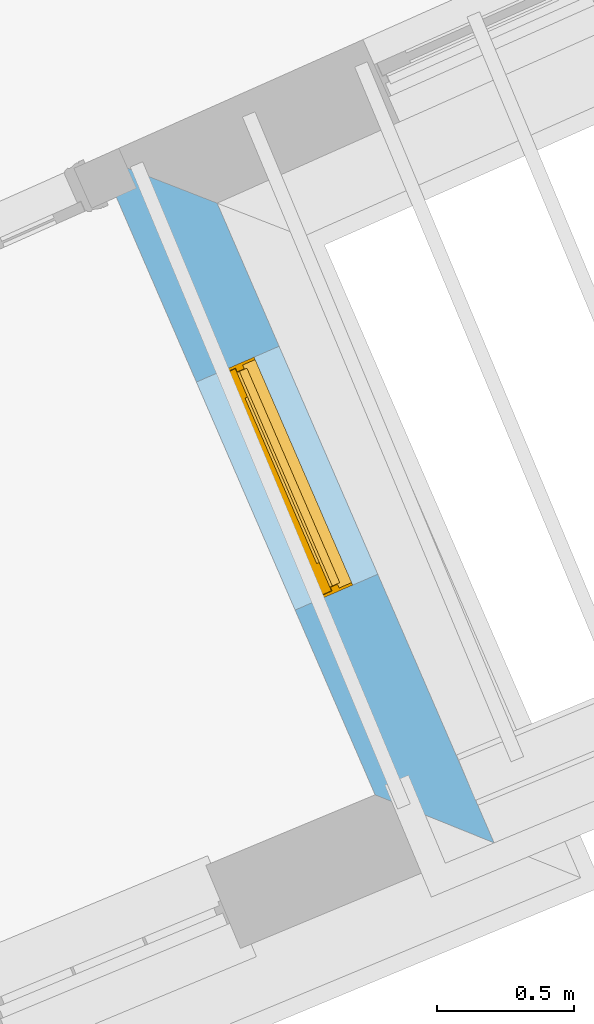
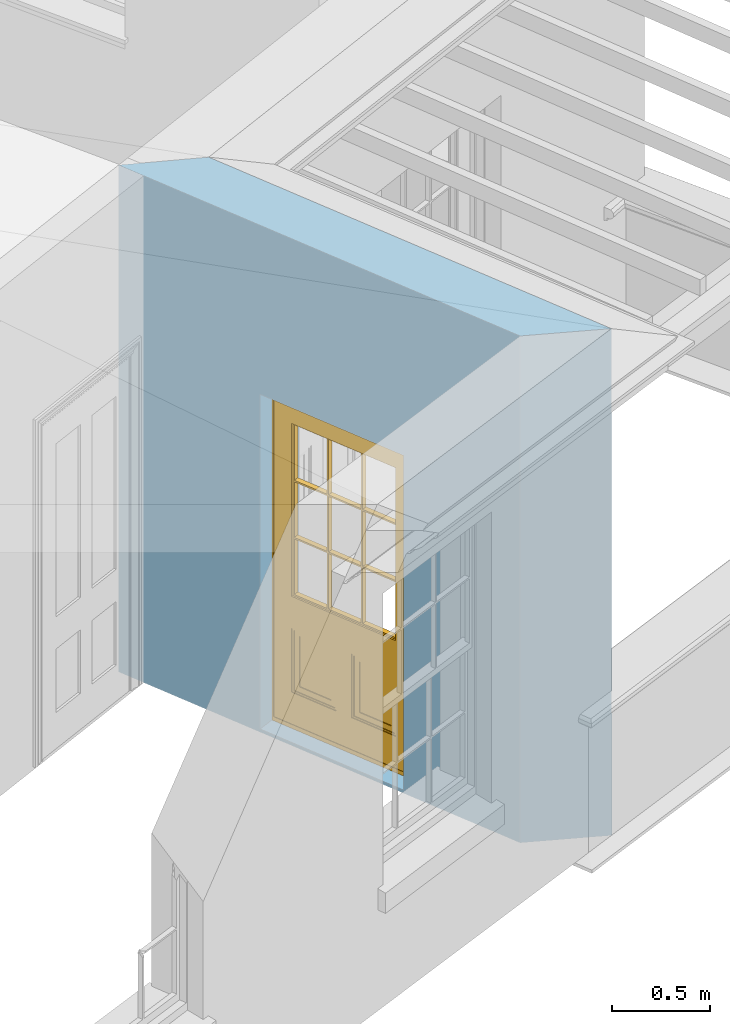
# One storey, part 5 of 10: 1 door, 1 opening, plus 1 element that does not belong to this part.
"""IFC2X3 building model written with IfcOpenShell, lengths in metres."""

from ifc_helpers import new_model, si_unit, frame, origin, place, context, subcontext, project, spatial, polyline, outline, extrude, faceted_brep, material, layer, layer_set, layer_usage, element, fill, save


model = new_model("IFC2X3")

# Units and contexts
model_context = context("Model", 3, world=origin())
body_context = subcontext(model_context, "Body", "Model", "MODEL_VIEW")
ifc_project = project(units=[si_unit("PLANEANGLEUNIT", "RADIAN"), si_unit("MASSUNIT", "GRAM", prefix="KILO"), si_unit("FORCEUNIT", "NEWTON", prefix="KILO"), si_unit("LENGTHUNIT", "METRE")], contexts=[model_context])

# Site, building, storey
site_placement = place(None, origin())
site = spatial("IfcSite", under=ifc_project, at=site_placement, CompositionType="ELEMENT")
building_placement = place(None, origin())
building = spatial("IfcBuilding", under=site, at=building_placement, Name="Building plot-1", CompositionType="ELEMENT")
storey_placement = place(None, frame((0.0, 0.0, 8.45)))
storey = spatial("IfcBuildingStorey", under=building, at=storey_placement, Name="Floor 2", CompositionType="ELEMENT", Elevation=8.45)

# Wall, opening, door
ifc_material = material(Name="Masonry")
ifc_layer = layer(ifc_material, 0.33, ventilated=False)
ifc_layer_set = layer_set([ifc_layer], Name="My Wall")
ifc_layer_usage = layer_usage(ifc_layer_set, "AXIS2", "NEGATIVE", 0.08)
wall_placement = place(storey_placement, origin())
wall = element("IfcWallStandardCase", 1, at=wall_placement, inside=storey, material=ifc_layer_usage, Name="exterior", context=body_context, shape_type="SweptSolid", body=[
    extrude(outline(polyline([(28.6286616795671, 43.2204467376737), (29.0644458342875, 43.0445099541443), (28.0499575041078, 45.3875090802526), (27.617356280873, 45.5560947632642), (28.6286616795671, 43.2204467376737)])), origin(), (0.0, 0.0, 1.0), 3.15),
])
opening_placement = place(storey_placement, frame((0.0, 0.0, 0.0199999999999996)))
opening = element("IfcOpeningElement", 2, at=opening_placement, cuts=wall, Name="Opening", ObjectType="Opening", context=body_context, shape_type="SweptSolid", body=[
    extrude(outline(polyline([(28.6384753465714, 44.0283048887692), (28.2768960371276, 44.8633859644631), (27.9740644382496, 44.7322637973022), (28.3356437476933, 43.8971827216083), (28.6384753465714, 44.0283048887692)])), origin(), (0.0, 0.0, 1.0), 2.08),
])
door_placement = place(storey_placement, frame((28.4090574686335, 43.9289699136473, 0.0199999999999996), z_axis=(0.0, 0.0, 1.0), x_axis=(-0.361579309443719, 0.835081075693971, 0.0)))
door = element("IfcDoor", 3, at=door_placement, inside=storey, Name="circulation outside door", OverallHeight=2.08, OverallWidth=0.91, context=body_context, shape_type="Brep", held_by="IfcProductRepresentation", body=[
    faceted_brep([(0.545, -0.055, 0.265), (0.745, -0.055, 0.265), (0.745, -0.05, 0.265), (0.545, -0.05, 0.265), (0.745, -0.05, 0.58), (0.545, -0.05, 0.58), (0.545, -0.055, 0.58), (0.515, -0.06, 0.235), (0.775, -0.06, 0.235), (0.745, -0.055, 0.58), (0.515, -0.06, 0.61), (0.515, -0.065, 0.235), (0.775, -0.065, 0.235), (0.775, -0.06, 0.61), (0.515, -0.065, 0.61), (0.785, -0.065, 0.225), (0.505, -0.065, 0.225), (0.775, -0.065, 0.61), (0.505, -0.065, 0.62), (0.785, -0.065, 0.62), (0.505, -0.07, 0.225), (0.785, -0.07, 0.225), (0.505, -0.07, 0.62), (0.785, -0.07, 0.62), (0.883, -0.07, 0.075), (0.898, -0.07, 0.075), (0.405, -0.07, 0.62), (0.405, -0.07, 0.225), (0.027, -0.07, 0.075), (0.785, -0.07, 0.82), (0.125, -0.07, 0.82), (0.405, -0.065, 0.62), (0.405, -0.065, 0.225), (0.898, -0.07, 2.068), (0.027, -0.08, 0.075), (0.883, -0.08, 0.075), (0.125, -0.07, 0.225), (0.012, -0.07, 0.075), (0.785, -0.06, 0.82), (0.125, -0.06, 0.82), (0.125, -0.07, 0.62), (0.125, -0.065, 0.62), (0.395, -0.065, 0.61), (0.395, -0.065, 0.235), (0.125, -0.065, 0.225), (0.785, -0.07, 1.895), (0.027, -0.11, 0.045), (0.883, -0.11, 0.045), (0.558333, -0.06, 0.83), (0.351667, -0.06, 0.83), (0.125, -0.07, 1.895), (0.125, -0.06, 1.895), (0.785, -0.06, 1.895), (0.012, -0.07, 2.068), (0.135, -0.065, 0.61), (0.395, -0.06, 0.61), (0.395, -0.06, 0.235), (0.135, -0.065, 0.235), (0.027, -0.11, 0.027), (0.883, -0.11, 0.027), (0.568333, -0.06, 0.83), (0.558333, -0.03, 0.83), (0.351667, -0.03, 0.83), (0.341667, -0.06, 0.83), (0.135, -0.06, 1.185), (0.135, -0.06, 1.53), (0.775, -0.06, 1.53), (0.775, -0.06, 1.185), (0.135, -0.06, 0.61), (0.365, -0.055, 0.58), (0.365, -0.055, 0.265), (0.135, -0.06, 0.235), (0.568333, -0.06, 1.175), (0.558333, -0.06, 1.175), (0.775, -0.06, 0.83), (0.558333, -0.03, 1.175), (0.785, -0.03, 0.82), (0.125, -0.03, 0.82), (0.351667, -0.03, 1.175), (0.351667, -0.06, 1.175), (0.341667, -0.06, 1.175), (0.135, -0.06, 0.83), (0.135, -0.06, 1.175), (0.135, -0.03, 1.185), (0.135, -0.03, 1.53), (0.135, -0.06, 1.54), (0.351667, -0.06, 1.885), (0.558333, -0.06, 1.885), (0.775, -0.03, 1.53), (0.775, -0.03, 1.185), (0.775, -0.06, 1.175), (0.775, -0.06, 1.54), (0.165, -0.055, 0.58), (0.365, -0.05, 0.58), (0.365, -0.05, 0.265), (0.165, -0.055, 0.265), (0.568333, -0.03, 0.83), (0.568333, -0.03, 1.175), (0.568333, -0.06, 1.185), (0.558333, -0.06, 1.185), (0.775, -0.03, 0.83), (0.785, -0.02, 0.82), (0.125, -0.02, 0.82), (0.341667, -0.03, 0.83), (0.341667, -0.03, 1.175), (0.351667, -0.06, 1.185), (0.341667, -0.06, 1.185), (0.135, -0.03, 0.83), (0.341667, -0.03, 1.185), (0.125, -0.03, 1.895), (0.341667, -0.03, 1.53), (0.341667, -0.06, 1.53), (0.135, -0.06, 1.885), (0.341667, -0.06, 1.54), (0.341667, -0.06, 1.885), (0.558333, -0.03, 1.885), (0.351667, -0.03, 1.885), (0.568333, -0.06, 1.885), (0.785, -0.03, 1.895), (0.568333, -0.03, 1.185), (0.568333, -0.06, 1.53), (0.568333, -0.03, 1.53), (0.568333, -0.06, 1.54), (0.775, -0.06, 1.885), (0.165, -0.05, 0.58), (0.165, -0.05, 0.265), (0.775, -0.03, 1.175), (0.558333, -0.06, 1.53), (0.351667, -0.03, 1.185), (0.558333, -0.03, 1.185), (0.505, -0.02, 0.62), (0.405, -0.02, 0.62), (0.125, -0.02, 1.895), (0.785, -0.02, 1.895), (0.351667, -0.06, 1.53), (0.135, -0.03, 1.175), (0.135, -0.03, 1.54), (0.341667, -0.03, 1.54), (0.135, -0.03, 1.885), (0.351667, -0.06, 1.54), (0.558333, -0.03, 1.54), (0.558333, -0.06, 1.54), (0.351667, -0.03, 1.54), (0.775, -0.03, 1.54), (0.568333, -0.03, 1.54), (0.775, -0.03, 1.885), (0.558333, -0.03, 1.53), (0.405, -0.02, 0.225), (0.505, -0.02, 0.225), (0.125, -0.02, 0.62), (0.785, -0.02, 0.62), (0.012, -0.02, 2.068), (0.898, -0.02, 2.068), (0.351667, -0.03, 1.53), (0.341667, -0.03, 1.885), (0.568333, -0.03, 1.885), (0.405, -0.025, 0.225), (0.405, -0.025, 0.62), (0.505, -0.025, 0.62), (0.505, -0.025, 0.225), (0.898, -0.02, 0.027), (0.012, -0.02, 0.027), (0.125, -0.025, 0.62), (0.785, -0.025, 0.62), (0.395, -0.025, 0.235), (0.395, -0.025, 0.61), (0.125, -0.02, 0.225), (0.125, -0.025, 0.225), (0.515, -0.025, 0.61), (0.515, -0.025, 0.235), (0.785, -0.02, 0.225), (0.785, -0.025, 0.225), (0.135, -0.025, 0.61), (0.775, -0.025, 0.61), (0.135, -0.025, 0.235), (0.395, -0.03, 0.235), (0.395, -0.03, 0.61), (0.515, -0.03, 0.61), (0.515, -0.03, 0.235), (0.775, -0.025, 0.235), (0.135, -0.03, 0.61), (0.775, -0.03, 0.61), (0.135, -0.03, 0.235), (0.365, -0.035, 0.265), (0.365, -0.035, 0.58), (0.545, -0.035, 0.58), (0.545, -0.035, 0.265), (0.775, -0.03, 0.235), (0.165, -0.035, 0.58), (0.745, -0.035, 0.58), (0.165, -0.035, 0.265), (0.365, -0.04, 0.58), (0.365, -0.04, 0.265), (0.545, -0.04, 0.58), (0.545, -0.04, 0.265), (0.745, -0.035, 0.265), (0.165, -0.04, 0.58), (0.745, -0.04, 0.58), (0.165, -0.04, 0.265), (0.745, -0.04, 0.265), (0.885, -0.072, 0.025), (0.025, -0.072, 0.025), (0.025, -0.1, 0.025), (0.885, -0.1, 0.025), (0.9, -0.02, 0.025), (0.01, -0.02, 0.025), (0.9, -0.072, 0.025), (0.91, -0.02, 0.0), (0.0, -0.02, 0.0), (0.01, -0.072, 0.025), (0.9, -0.072, 2.07), (0.9, -0.02, 2.07), (0.885, -0.072, 2.055), (0.91, -0.02, 2.08), (0.01, -0.02, 2.07), (0.0, -0.02, 2.08), (0.01, -0.072, 2.07), (0.025, -0.072, 2.055), (0.0, -0.15, 2.08), (0.91, -0.15, 2.08), (0.01, -0.15, 2.07), (0.9, -0.15, 2.07), (0.01, -0.1, 2.07), (0.9, -0.1, 2.07), (0.0, -0.15, 0.0), (0.91, -0.15, 0.0), (0.01, -0.15, 0.025), (0.9, -0.15, 0.025), (0.01, -0.1, 0.025), (0.025, -0.1, 2.055), (0.9, -0.1, 0.025), (0.885, -0.1, 2.055), (0.898, -0.07, 0.027), (0.012, -0.07, 0.027), (0.883, -0.07, 0.027), (0.027, -0.07, 0.027)], [[[0, 1, 2, 3]], [[2, 4, 5, 3]], [[0, 3, 5, 6]], [[1, 0, 7, 8]], [[9, 4, 2, 1]], [[9, 6, 5, 4]], [[0, 6, 10, 7]], [[8, 7, 11, 12]], [[8, 13, 9, 1]], [[13, 10, 6, 9]], [[7, 10, 14, 11]], [[15, 12, 11, 16]], [[12, 17, 13, 8]], [[17, 14, 10, 13]], [[18, 16, 11, 14]], [[15, 19, 17, 12]], [[15, 16, 20, 21]], [[14, 17, 19, 18]], [[16, 18, 22, 20]], [[21, 23, 19, 15]], [[24, 25, 21, 20]], [[23, 22, 18, 19]], [[20, 22, 26, 27]], [[23, 21, 25]], [[28, 24, 20, 27]], [[22, 23, 29]], [[29, 30, 26, 22]], [[27, 26, 31, 32]], [[23, 25, 33, 29]], [[34, 35, 24, 28]], [[28, 27, 36, 37]], [[38, 39, 30, 29]], [[26, 30, 40]], [[26, 40, 41, 31]], [[42, 43, 32, 31]], [[32, 44, 36, 27]], [[33, 45, 29]], [[46, 47, 35, 34]], [[36, 40, 37]], [[39, 38, 48, 49]], [[50, 30, 39, 51]], [[29, 45, 52, 38]], [[53, 37, 40, 30]], [[44, 41, 40, 36]], [[31, 41, 54, 42]], [[43, 42, 55, 56]], [[57, 44, 32, 43]], [[50, 45, 33, 53]], [[47, 46, 58, 59]], [[60, 48, 38]], [[49, 48, 61, 62]], [[49, 63, 39]], [[50, 53, 30]], [[51, 39, 64, 65]], [[45, 50, 51, 52]], [[66, 67, 38, 52]], [[57, 54, 41, 44]], [[42, 54, 68, 55]], [[56, 55, 69, 70]], [[56, 71, 57, 43]], [[60, 72, 73, 48]], [[60, 38, 74]], [[48, 73, 75, 61]], [[76, 77, 62, 61]], [[62, 78, 79, 49]], [[49, 79, 80, 63]], [[63, 81, 39]], [[82, 64, 39]], [[65, 64, 83, 84]], [[85, 51, 65]], [[52, 51, 86, 87]], [[88, 89, 67, 66]], [[90, 38, 67]], [[91, 66, 52]], [[71, 68, 54, 57]], [[55, 68, 92, 69]], [[69, 93, 94, 70]], [[70, 95, 71, 56]], [[96, 97, 72, 60]], [[73, 72, 98, 99]], [[74, 38, 90]], [[100, 96, 60, 74]], [[75, 73, 79, 78]], [[61, 75, 97, 96]], [[101, 102, 77, 76]], [[77, 103, 62]], [[96, 76, 61]], [[103, 104, 78, 62]], [[80, 79, 105, 106]], [[63, 80, 104, 103]], [[81, 63, 103, 107]], [[81, 82, 39]], [[106, 64, 82, 80]], [[106, 108, 83, 64]], [[84, 83, 77, 109]], [[110, 111, 65, 84]], [[112, 51, 85]], [[113, 85, 65, 111]], [[114, 86, 51]], [[115, 87, 86, 116]], [[117, 52, 87]], [[118, 76, 89, 88]], [[119, 98, 67, 89]], [[120, 121, 88, 66]], [[67, 98, 72, 90]], [[91, 122, 120, 66]], [[91, 52, 123]], [[95, 92, 68, 71]], [[69, 92, 124, 93]], [[94, 93, 124, 125]], [[94, 125, 95, 70]], [[72, 97, 126, 90]], [[127, 99, 98, 120]], [[99, 105, 79, 73]], [[74, 90, 126, 100]], [[96, 100, 76]], [[128, 129, 75, 78]], [[97, 75, 129, 119]], [[130, 131, 102, 101]], [[109, 77, 102, 132]], [[133, 101, 76, 118]], [[77, 107, 103]], [[78, 104, 108, 128]], [[111, 106, 105, 134]], [[104, 80, 82, 135]], [[107, 135, 82, 81]], [[110, 108, 106, 111]], [[104, 135, 83, 108]], [[83, 135, 77]], [[136, 84, 109]], [[110, 84, 136, 137]], [[114, 51, 112]], [[85, 136, 138, 112]], [[113, 137, 136, 85]], [[111, 134, 139, 113]], [[86, 114, 113, 139]], [[140, 141, 87, 115]], [[139, 142, 116, 86]], [[109, 118, 115, 116]], [[117, 123, 52]], [[117, 87, 141, 122]], [[126, 89, 76]], [[143, 118, 88]], [[120, 98, 119, 121]], [[119, 89, 126, 97]], [[144, 143, 88, 121]], [[144, 122, 91, 143]], [[127, 120, 122, 141]], [[143, 91, 123, 145]], [[124, 92, 95, 125]], [[146, 129, 99, 127]], [[99, 129, 128, 105]], [[100, 126, 76]], [[121, 119, 129, 146]], [[147, 131, 130, 148]], [[131, 149, 102]], [[130, 101, 150]], [[102, 151, 132]], [[118, 109, 132, 133]], [[101, 133, 152]], [[107, 77, 135]], [[153, 128, 108, 110]], [[134, 105, 128, 153]], [[109, 138, 136]], [[153, 110, 137, 142]], [[154, 114, 112, 138]], [[137, 113, 114, 154]], [[141, 139, 134, 127]], [[141, 140, 142, 139]], [[144, 140, 115, 155]], [[142, 137, 154, 116]], [[155, 115, 118]], [[116, 154, 109]], [[117, 155, 145, 123]], [[122, 144, 155, 117]], [[143, 145, 118]], [[121, 146, 140, 144]], [[146, 127, 134, 153]], [[156, 157, 131, 147]], [[148, 130, 158, 159]], [[148, 160, 161, 147]], [[157, 162, 149, 131]], [[161, 151, 102, 149]], [[101, 152, 160, 150]], [[163, 158, 130, 150]], [[151, 152, 133, 132]], [[154, 138, 109]], [[142, 140, 146, 153]], [[145, 155, 118]], [[157, 156, 164, 165]], [[147, 166, 167, 156]], [[168, 169, 159, 158]], [[170, 148, 159, 171]], [[148, 170, 160]], [[166, 147, 161]], [[172, 162, 157, 165]], [[166, 149, 162, 167]], [[166, 161, 149]], [[150, 160, 170]], [[163, 173, 168, 158]], [[171, 163, 150, 170]], [[174, 164, 156, 167]], [[175, 176, 165, 164]], [[169, 168, 177, 178]], [[171, 159, 169, 179]], [[167, 162, 172, 174]], [[176, 180, 172, 165]], [[179, 173, 163, 171]], [[181, 177, 168, 173]], [[164, 174, 182, 175]], [[183, 184, 176, 175]], [[178, 177, 185, 186]], [[179, 169, 178, 187]], [[174, 172, 180, 182]], [[184, 188, 180, 176]], [[187, 181, 173, 179]], [[189, 185, 177, 181]], [[175, 182, 190, 183]], [[191, 184, 183, 192]], [[185, 193, 194, 186]], [[187, 178, 186, 195]], [[182, 180, 188, 190]], [[191, 196, 188, 184]], [[195, 189, 181, 187]], [[197, 193, 185, 189]], [[183, 190, 198, 192]], [[198, 196, 191, 192]], [[194, 193, 197, 199]], [[195, 186, 194, 199]], [[188, 196, 198, 190]], [[197, 189, 195, 199]], [[200, 201, 202, 203]], [[201, 200, 204, 205]], [[206, 204, 200]], [[204, 207, 208, 205]], [[209, 201, 205]], [[210, 211, 204, 206]], [[206, 200, 212, 210]], [[211, 213, 207, 204]], [[214, 205, 208, 215]], [[216, 217, 201, 209]], [[205, 214, 216, 209]], [[216, 214, 211, 210]], [[210, 212, 217, 216]], [[214, 215, 213, 211]], [[218, 219, 213, 215]], [[219, 218, 220, 221]], [[221, 220, 222, 223]], [[215, 208, 224, 218]], [[225, 224, 208, 207]], [[224, 226, 220, 218]], [[224, 225, 227, 226]], [[219, 225, 207, 213]], [[228, 222, 220, 226]], [[219, 221, 227, 225]], [[226, 227, 203, 202]], [[202, 229, 222, 228]], [[228, 226, 202]], [[227, 221, 223, 230]], [[230, 203, 227]], [[217, 229, 202, 201]], [[231, 223, 222, 229]], [[230, 223, 231, 203]], [[231, 229, 217, 212]], [[212, 200, 203, 231]], [[33, 152, 151, 53]], [[25, 160, 152, 33]], [[161, 37, 53, 151]], [[232, 160, 25]], [[161, 233, 37]], [[160, 232, 234]], [[24, 234, 232, 25]], [[233, 161, 235]], [[37, 233, 235, 28]], [[161, 160, 234, 235]], [[35, 47, 234, 24]], [[28, 235, 46, 34]], [[58, 235, 234, 59]], [[59, 234, 47]], [[58, 46, 235]]]),
])
fill(opening, door)

save(model, "model.ifc")
